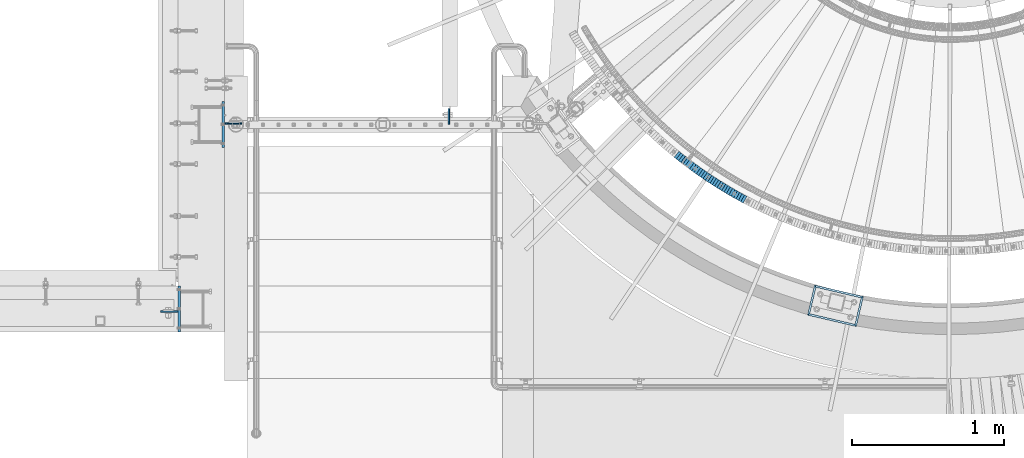
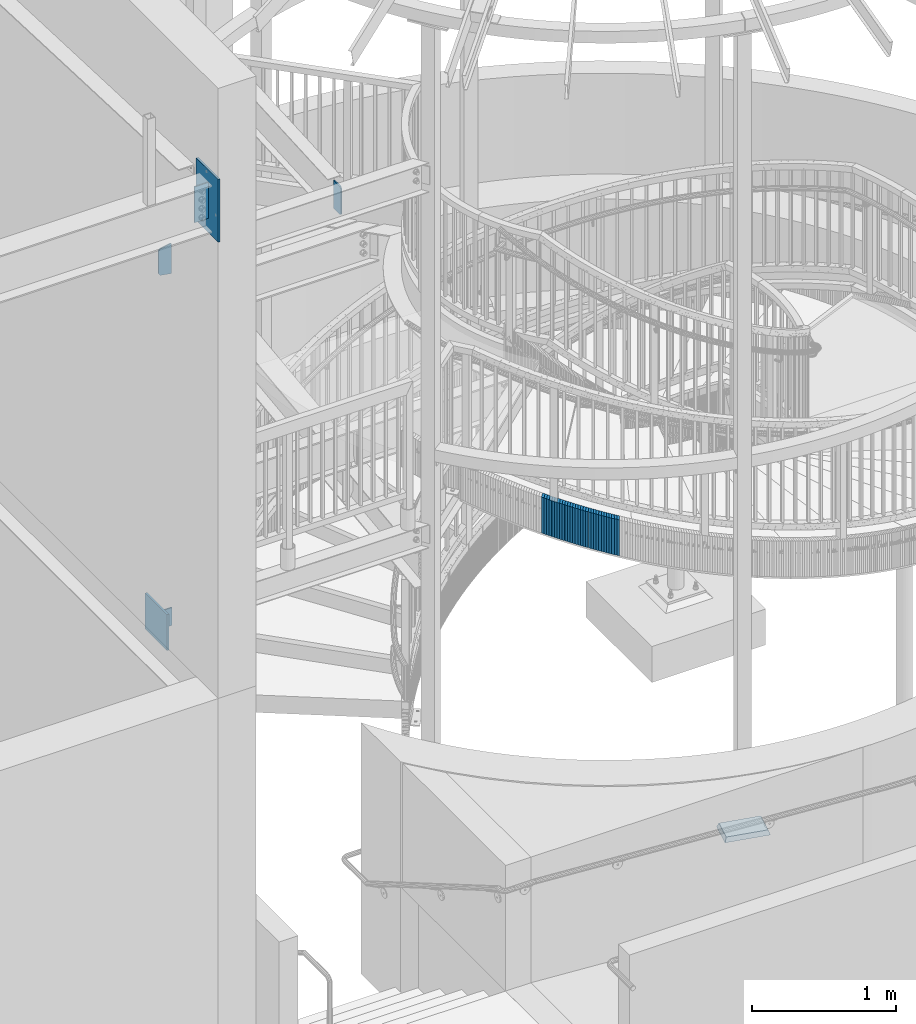
# One storey, part 873 of 975: 37 plates.
"""IFC2X3 building model written with IfcOpenShell, lengths in millimetres."""

from ifc_helpers import new_model, si_unit, frame, origin_with_axes, place, context, subcontext, project, spatial, faceted_brep, material, type_object, element, save


model = new_model("IFC2X3")

# Units and contexts
model_context = context("Model", 3, precision=1e-05, world=origin_with_axes())
body_context = subcontext(model_context, "Body", "Model", "MODEL_VIEW")
ifc_project = project(units=[si_unit("LENGTHUNIT", "METRE", prefix="MILLI"), si_unit("AREAUNIT", "SQUARE_METRE"), si_unit("VOLUMEUNIT", "CUBIC_METRE"), si_unit("MASSUNIT", "GRAM", prefix="KILO"), si_unit("TIMEUNIT", "SECOND"), si_unit("PLANEANGLEUNIT", "RADIAN"), si_unit("SOLIDANGLEUNIT", "STERADIAN"), si_unit("THERMODYNAMICTEMPERATUREUNIT", "DEGREE_CELSIUS"), si_unit("LUMINOUSINTENSITYUNIT", "LUMEN")], contexts=[model_context])

# Site, building, storey
site_placement = place(None, origin_with_axes())
site = spatial("IfcSite", under=ifc_project, at=site_placement, CompositionType="ELEMENT")
building_placement = place(site_placement, origin_with_axes())
building = spatial("IfcBuilding", under=site, at=building_placement, Name="Undefined", CompositionType="ELEMENT")
storey_placement = place(building_placement, origin_with_axes())
storey = spatial("IfcBuildingStorey", under=building, at=storey_placement, Name="Undefined", CompositionType="ELEMENT", Elevation=0.0)

# Plates
ifc_material_1 = material(Name="STEEL/A36")
plate_type_1 = type_object("IfcPlateType", PredefinedType="NOTDEFINED")
plate_1_placement = place(storey_placement, frame((29965.9498440442, 1372.15213761205, 6767.67232410142), z_axis=(0.164483633078449, 0.0, 0.986379812470488), x_axis=(0.986379812470487, 0.0, -0.16448363307845)))
element("IfcPlate", 1, at=plate_1_placement, inside=storey, type_object=plate_type_1, material=ifc_material_1, Name="PLATE", context=body_context, shape_type="Brep", body=[
    faceted_brep([(-2.35006011738005, -4.76249999999982, 14.0929019224332), (-34.1783212304363, -4.76249999999982, 204.961449884235), (-34.1783212304363, 4.76249999999982, 204.961449884235), (-2.35006011738005, 4.76249999999982, 14.0929019224332), (-23.0139741568892, -4.76249999999982, 223.690456359918), (-23.0139741568892, 4.76249999999982, 223.690456359918), (60.9010810849977, -4.76249999997867, 252.477432251004), (60.901081085005, 4.76250000002142, 252.477432251006), (103.002922058127, -4.762499999998, 2.72848410531878e-11), (103.002922058138, 4.76250000000186, 2.72848410531878e-11), (14.2875003814897, -4.76249999997526, 9.09494701772928e-12), (14.2875003814825, 4.76250000001892, 9.09494701772928e-12)], [[[0, 1, 2, 3]], [[1, 4, 5, 2]], [[4, 6, 7, 5]], [[6, 8, 9, 7]], [[8, 10, 11, 9]], [[10, 0, 3, 11]], [[5, 7, 9, 11, 3, 2]], [[10, 8, 6, 4, 1, 0]]]),
])
plate_2_placement = place(storey_placement, frame((31434.8810365989, 1367.38914717561, 6764.33750000007), z_axis=(0.0, 0.0, 1.0), x_axis=(0.0, 1.0, 0.0)))
element("IfcPlate", 2, at=plate_2_placement, inside=storey, type_object=plate_type_1, material=ifc_material_1, Name="PLATE", context=body_context, shape_type="Brep", body=[
    faceted_brep([(4.54747350886464e-13, -4.76250000000437, 14.2875003814697), (4.54747350886464e-13, -4.76250000000437, 227.012502670288), (0.0, 4.76249999999709, 227.012502670288), (0.0, 4.76249999999709, 14.2875003814697), (14.2875003814702, -4.76250000002983, 241.300003051758), (14.2875003814697, 4.76249999997162, 241.300003051758), (101.599998474122, -4.7625000001608, 241.300003051758), (101.599998474121, 4.76249999984066, 241.300003051758), (101.600006103516, -4.76250000000073, 0.0), (101.600006103516, 4.76250000000073, 0.0), (14.2875003814897, -4.76249999997526, 9.09494701772928e-12), (14.2875003814825, 4.76250000001892, 9.09494701772928e-12)], [[[0, 1, 2, 3]], [[1, 4, 5, 2]], [[4, 6, 7, 5]], [[6, 8, 9, 7]], [[8, 10, 11, 9]], [[10, 0, 3, 11]], [[5, 7, 9, 11, 3, 2]], [[10, 8, 6, 4, 1, 0]]]),
])
plate_type_2 = type_object("IfcPlateType", PredefinedType="NOTDEFINED")
plate_3_placement = place(storey_placement, frame((32945.7241902459, 1158.46817278171, 3676.3875000677), z_axis=(-0.780868809052787, 0.624695048042229, 0.0), x_axis=(0.0, 0.0, 1.0)))
element("IfcPlate", 3, at=plate_3_placement, inside=storey, type_object=plate_type_2, material=ifc_material_1, Name="WALL", context=body_context, shape_type="Brep", body=[
    faceted_brep([(0.0, -25.3999999999724, -1.81898940354586e-11), (5.80000019073486, -25.3999999999833, 17.9287471770986), (5.80000019073486, 25.4000000000087, 17.9287471771167), (0.0, 25.3999999999869, 1.45519152283669e-11), (310.600006103516, -25.3999999999833, 17.9287471770986), (310.600006103516, 25.4000000000087, 17.9287471771167), (304.799987792969, -25.3999999999724, -1.81898940354586e-11), (304.799987792969, 25.3999999999869, 1.45519152283669e-11)], [[[0, 1, 2, 3]], [[1, 4, 5, 2]], [[4, 6, 7, 5]], [[6, 0, 3, 7]], [[5, 7, 3, 2]], [[6, 4, 1, 0]]]),
])
plate_4_placement = place(storey_placement, frame((32959.8110283634, 1147.29901297474, 3670.6875000677), z_axis=(-0.783591636094264, 0.621276225074736, 0.0), x_axis=(0.0, 0.0, 1.0)))
element("IfcPlate", 4, at=plate_4_placement, inside=storey, type_object=plate_type_2, material=ifc_material_1, Name="WALL", context=body_context, shape_type="Brep", body=[
    faceted_brep([(0.0, -25.3999999999724, -1.81898940354586e-11), (5.69999980926514, -25.3999999999469, 17.8731651305425), (5.69999980926514, 25.3999999999869, 17.8731651306334), (0.0, 25.3999999999869, 1.45519152283669e-11), (310.5, -25.3999999999469, 17.8731651305425), (310.5, 25.3999999999869, 17.8731651306334), (304.799987792969, -25.3999999999724, -1.81898940354586e-11), (304.799987792969, 25.3999999999869, 1.45519152283669e-11)], [[[0, 1, 2, 3]], [[1, 4, 5, 2]], [[4, 6, 7, 5]], [[6, 0, 3, 7]], [[5, 7, 3, 2]], [[6, 4, 1, 0]]]),
])
plate_5_placement = place(storey_placement, frame((32974.2365418416, 1136.12227530397, 3664.9875000677), z_axis=(-0.79054981213442, 0.612397742104127, 0.0), x_axis=(0.0, 0.0, 1.0)))
element("IfcPlate", 5, at=plate_5_placement, inside=storey, type_object=plate_type_2, material=ifc_material_1, Name="WALL", context=body_context, shape_type="Brep", body=[
    faceted_brep([(0.0, -25.3999999999724, -1.81898940354586e-11), (5.69999980926514, -25.400000000016, 17.9627399444762), (5.69999980926514, 25.3999999999869, 17.9627399444762), (0.0, 25.3999999999869, 1.45519152283669e-11), (310.5, -25.400000000016, 17.9627399444762), (310.5, 25.3999999999869, 17.9627399444762), (304.799987792969, -25.3999999999724, -1.81898940354586e-11), (304.799987792969, 25.3999999999869, 1.45519152283669e-11)], [[[0, 1, 2, 3]], [[1, 4, 5, 2]], [[4, 6, 7, 5]], [[6, 0, 3, 7]], [[5, 7, 3, 2]], [[6, 4, 1, 0]]]),
])
plate_6_placement = place(storey_placement, frame((32988.5253707412, 1125.15377749335, 3659.1875000677), z_axis=(-0.793246576330857, 0.608900541253967, 0.0), x_axis=(0.0, 0.0, 1.0)))
element("IfcPlate", 6, at=plate_6_placement, inside=storey, type_object=plate_type_2, material=ifc_material_1, Name="WALL", context=body_context, shape_type="Brep", body=[
    faceted_brep([(0.0, -25.3999999999724, -1.81898940354586e-11), (5.80000019073486, -25.399999999936, 17.9011173247382), (5.80000019073486, 25.3999999999578, 17.9011173248837), (0.0, 25.3999999999869, 1.45519152283669e-11), (310.600006103516, -25.399999999936, 17.9011173247382), (310.600006103516, 25.3999999999578, 17.9011173248837), (304.799987792969, -25.3999999999724, -1.81898940354586e-11), (304.799987792969, 25.3999999999869, 1.45519152283669e-11)], [[[0, 1, 2, 3]], [[1, 4, 5, 2]], [[4, 6, 7, 5]], [[6, 0, 3, 7]], [[5, 7, 3, 2]], [[6, 4, 1, 0]]]),
])
plate_7_placement = place(storey_placement, frame((33002.8936910066, 1114.20151807421, 3653.3875000677), z_axis=(-0.795304033791869, 0.606210766841354, 0.0), x_axis=(0.0, 0.0, 1.0)))
element("IfcPlate", 7, at=plate_7_placement, inside=storey, type_object=plate_type_2, material=ifc_material_1, Name="WALL", context=body_context, shape_type="Brep", body=[
    faceted_brep([(0.0, -25.3999999999724, -1.81898940354586e-11), (5.80000019073486, -25.3999999999505, 17.9788761138298), (5.80000019073486, 25.4000000000196, 17.9788761138625), (0.0, 25.3999999999869, 1.45519152283669e-11), (310.600006103516, -25.3999999999505, 17.9788761138298), (310.600006103516, 25.4000000000196, 17.9788761138625), (304.799987792969, -25.3999999999724, -1.81898940354586e-11), (304.799987792969, 25.3999999999869, 1.45519152283669e-11)], [[[0, 1, 2, 3]], [[1, 4, 5, 2]], [[4, 6, 7, 5]], [[6, 0, 3, 7]], [[5, 7, 3, 2]], [[6, 4, 1, 0]]]),
])
plate_8_placement = place(storey_placement, frame((33017.2834945886, 1103.33338092226, 3647.6875000677), z_axis=(-0.797986598823975, 0.602675192867057, 0.0), x_axis=(0.0, 0.0, 1.0)))
element("IfcPlate", 8, at=plate_8_placement, inside=storey, type_object=plate_type_2, material=ifc_material_1, Name="WALL", context=body_context, shape_type="Brep", body=[
    faceted_brep([(0.0, -25.3999999999724, -1.81898940354586e-11), (5.69999980926514, -25.3999999999724, 17.9212169646999), (5.69999980926514, 25.3999999999651, 17.9212169647544), (0.0, 25.3999999999869, 1.45519152283669e-11), (310.5, -25.3999999999724, 17.9212169646999), (310.5, 25.3999999999651, 17.9212169647544), (304.799987792969, -25.3999999999724, -1.81898940354586e-11), (304.799987792969, 25.3999999999869, 1.45519152283669e-11)], [[[0, 1, 2, 3]], [[1, 4, 5, 2]], [[4, 6, 7, 5]], [[6, 0, 3, 7]], [[5, 7, 3, 2]], [[6, 4, 1, 0]]]),
])
plate_9_placement = place(storey_placement, frame((33031.6742087829, 1092.56518721397, 3641.9875000677), z_axis=(-0.800671390520529, 0.599103767641235, 0.0), x_axis=(0.0, 0.0, 1.0)))
element("IfcPlate", 9, at=plate_9_placement, inside=storey, type_object=plate_type_2, material=ifc_material_1, Name="WALL", context=body_context, shape_type="Brep", body=[
    faceted_brep([(0.0, -25.3999999999724, -1.81898940354586e-11), (5.69999980926514, -25.4000000000378, 17.8639297485788), (5.69999980926514, 25.3999999999833, 17.8639297485533), (0.0, 25.3999999999869, 1.45519152283669e-11), (310.5, -25.4000000000378, 17.8639297485788), (310.5, 25.3999999999833, 17.8639297485533), (304.799987792969, -25.3999999999724, -1.81898940354586e-11), (304.799987792969, 25.3999999999869, 1.45519152283669e-11)], [[[0, 1, 2, 3]], [[1, 4, 5, 2]], [[4, 6, 7, 5]], [[6, 0, 3, 7]], [[5, 7, 3, 2]], [[6, 4, 1, 0]]]),
])
plate_10_placement = place(storey_placement, frame((33046.4014777338, 1081.79709734652, 3636.1875000677), z_axis=(-0.807289101847685, 0.590156170888654, 0.0), x_axis=(0.0, 0.0, 1.0)))
element("IfcPlate", 10, at=plate_10_placement, inside=storey, type_object=plate_type_2, material=ifc_material_1, Name="WALL", context=body_context, shape_type="Brep", body=[
    faceted_brep([(0.0, -25.3999999999724, -1.81898940354586e-11), (5.80000019073486, -25.399999999976, 17.9610691070338), (5.80000019073486, 25.4000000000269, 17.9610691070338), (0.0, 25.3999999999869, 1.45519152283669e-11), (310.600006103516, -25.399999999976, 17.9610691070338), (310.600006103516, 25.4000000000269, 17.9610691070338), (304.799987792969, -25.3999999999724, -1.81898940354586e-11), (304.799987792969, 25.3999999999869, 1.45519152283669e-11)], [[[0, 1, 2, 3]], [[1, 4, 5, 2]], [[4, 6, 7, 5]], [[6, 0, 3, 7]], [[5, 7, 3, 2]], [[6, 4, 1, 0]]]),
])
plate_11_placement = place(storey_placement, frame((33060.9940952527, 1071.22971064023, 3630.4875000677), z_axis=(-0.80994212177235, 0.58650981183515, 0.0), x_axis=(0.0, 0.0, 1.0)))
element("IfcPlate", 11, at=plate_11_placement, inside=storey, type_object=plate_type_2, material=ifc_material_1, Name="WALL", context=body_context, shape_type="Brep", body=[
    faceted_brep([(0.0, -25.3999999999724, -1.81898940354586e-11), (5.69999980926514, -25.3999999999978, 17.9011173248218), (5.69999980926514, 25.4000000000087, 17.9011173248182), (0.0, 25.3999999999869, 1.45519152283669e-11), (310.5, -25.3999999999978, 17.9011173248218), (310.5, 25.4000000000087, 17.9011173248182), (304.799987792969, -25.3999999999724, -1.81898940354586e-11), (304.799987792969, 25.3999999999869, 1.45519152283669e-11)], [[[0, 1, 2, 3]], [[1, 4, 5, 2]], [[4, 6, 7, 5]], [[6, 0, 3, 7]], [[5, 7, 3, 2]], [[6, 4, 1, 0]]]),
])
plate_12_placement = place(storey_placement, frame((33075.5876275221, 1060.76230342808, 3624.6875000677), z_axis=(-0.812595949007106, 0.582827439005097, 0.0), x_axis=(0.0, 0.0, 1.0)))
element("IfcPlate", 12, at=plate_12_placement, inside=storey, type_object=plate_type_2, material=ifc_material_1, Name="WALL", context=body_context, shape_type="Brep", body=[
    faceted_brep([(0.0, -25.3999999999724, -1.81898940354586e-11), (5.80000019073486, -25.3999999999614, 17.8392829894583), (5.80000019073486, 25.3999999999578, 17.8392829895529), (0.0, 25.3999999999869, 1.45519152283669e-11), (310.600006103516, -25.3999999999614, 17.8392829894583), (310.600006103516, 25.3999999999578, 17.8392829895529), (304.799987792969, -25.3999999999724, -1.81898940354586e-11), (304.799987792969, 25.3999999999869, 1.45519152283669e-11)], [[[0, 1, 2, 3]], [[1, 4, 5, 2]], [[4, 6, 7, 5]], [[6, 0, 3, 7]], [[5, 7, 3, 2]], [[6, 4, 1, 0]]]),
])
plate_13_placement = place(storey_placement, frame((33090.3492730024, 1050.34731787968, 3618.9875000677), z_axis=(-0.817122939119162, 0.576463444084065, 0.0), x_axis=(0.0, 0.0, 1.0)))
element("IfcPlate", 13, at=plate_13_placement, inside=storey, type_object=plate_type_2, material=ifc_material_1, Name="WALL", context=body_context, shape_type="Brep", body=[
    faceted_brep([(0.0, -25.3999999999724, -1.81898940354586e-11), (5.69999980926514, -25.3999999999469, 17.8731651305425), (5.69999980926514, 25.3999999999869, 17.8731651306334), (0.0, 25.3999999999869, 1.45519152283669e-11), (310.5, -25.3999999999469, 17.8731651305425), (310.5, 25.3999999999869, 17.8731651306334), (304.799987792969, -25.3999999999724, -1.81898940354586e-11), (304.799987792969, 25.3999999999869, 1.45519152283669e-11)], [[[0, 1, 2, 3]], [[1, 4, 5, 2]], [[4, 6, 7, 5]], [[6, 0, 3, 7]], [[5, 7, 3, 2]], [[6, 4, 1, 0]]]),
])
plate_14_placement = place(storey_placement, frame((33105.2113731661, 1040.03390244274, 3613.2875000677), z_axis=(-0.821588113820831, 0.570081547875679, 0.0), x_axis=(0.0, 0.0, 1.0)))
element("IfcPlate", 14, at=plate_14_placement, inside=storey, type_object=plate_type_2, material=ifc_material_1, Name="WALL", context=body_context, shape_type="Brep", body=[
    faceted_brep([(0.0, -25.3999999999724, -1.81898940354586e-11), (5.69999980926514, -25.3999999999614, 17.8921775817616), (5.69999980926514, 25.400000000016, 17.8921775817726), (0.0, 25.3999999999869, 1.45519152283669e-11), (310.5, -25.3999999999614, 17.8921775817616), (310.5, 25.400000000016, 17.8921775817726), (304.799987792969, -25.3999999999724, -1.81898940354586e-11), (304.799987792969, 25.3999999999869, 1.45519152283669e-11)], [[[0, 1, 2, 3]], [[1, 4, 5, 2]], [[4, 6, 7, 5]], [[6, 0, 3, 7]], [[5, 7, 3, 2]], [[6, 4, 1, 0]]]),
])
plate_15_placement = place(storey_placement, frame((33120.1738930212, 1029.82206608943, 3607.4875000677), z_axis=(-0.825991119901672, 0.563683128932898, 0.0), x_axis=(0.0, 0.0, 1.0)))
element("IfcPlate", 15, at=plate_15_placement, inside=storey, type_object=plate_type_2, material=ifc_material_1, Name="WALL", context=body_context, shape_type="Brep", body=[
    faceted_brep([(0.0, -25.3999999999724, -1.81898940354586e-11), (5.80000019073486, -25.4000000000233, 17.9178676605334), (5.80000019073486, 25.3999999999942, 17.9178676605297), (0.0, 25.3999999999869, 1.45519152283669e-11), (310.600006103516, -25.4000000000233, 17.9178676605334), (310.600006103516, 25.3999999999942, 17.9178676605297), (304.799987792969, -25.3999999999724, -1.81898940354586e-11), (304.799987792969, 25.3999999999869, 1.45519152283669e-11)], [[[0, 1, 2, 3]], [[1, 4, 5, 2]], [[4, 6, 7, 5]], [[6, 0, 3, 7]], [[5, 7, 3, 2]], [[6, 4, 1, 0]]]),
])
plate_16_placement = place(storey_placement, frame((33135.0710662587, 1019.75608072524, 3601.7875000677), z_axis=(-0.828588968736746, 0.559857411210905, -1.04603259387659e-10), x_axis=(0.0, 0.0, 1.0)))
element("IfcPlate", 16, at=plate_16_placement, inside=storey, type_object=plate_type_2, material=ifc_material_1, Name="WALL", context=body_context, shape_type="Brep", body=[
    faceted_brep([(0.0, -25.3999999999724, -1.81898940354586e-11), (5.69999980926514, -25.4000000000378, 17.8639297485788), (5.69999980926514, 25.3999999999833, 17.8639297485533), (0.0, 25.3999999999869, 1.45519152283669e-11), (310.5, -25.4000000000378, 17.8639297485788), (310.5, 25.3999999999833, 17.8639297485533), (304.799987792969, -25.3999999999724, -1.81898940354586e-11), (304.799987792969, 25.3999999999869, 1.45519152283669e-11)], [[[0, 1, 2, 3]], [[1, 4, 5, 2]], [[4, 6, 7, 5]], [[6, 0, 3, 7]], [[5, 7, 3, 2]], [[6, 4, 1, 0]]]),
])
plate_17_placement = place(storey_placement, frame((33149.9691575141, 1009.79013475099, 3596.0875000677), z_axis=(-0.831185267125649, 0.555995550084048, 0.0), x_axis=(0.0, 0.0, 1.0)))
element("IfcPlate", 17, at=plate_17_placement, inside=storey, type_object=plate_type_2, material=ifc_material_1, Name="WALL", context=body_context, shape_type="Brep", body=[
    faceted_brep([(0.0, -25.3999999999724, -1.81898940354586e-11), (5.69999980926514, -25.4000000000306, 17.8058986664291), (5.69999980926514, 25.4000000000415, 17.80589866632), (0.0, 25.3999999999869, 1.45519152283669e-11), (310.5, -25.4000000000306, 17.8058986664291), (310.5, 25.4000000000415, 17.80589866632), (304.799987792969, -25.3999999999724, -1.81898940354586e-11), (304.799987792969, 25.3999999999869, 1.45519152283669e-11)], [[[0, 1, 2, 3]], [[1, 4, 5, 2]], [[4, 6, 7, 5]], [[6, 0, 3, 7]], [[5, 7, 3, 2]], [[6, 4, 1, 0]]]),
])
plate_18_placement = place(storey_placement, frame((33165.0338012818, 999.880925872626, 3590.2875000677), z_axis=(-0.835484829267466, 0.549513512175918, 0.0), x_axis=(0.0, 0.0, 1.0)))
element("IfcPlate", 18, at=plate_18_placement, inside=storey, type_object=plate_type_2, material=ifc_material_1, Name="WALL", context=body_context, shape_type="Brep", body=[
    faceted_brep([(0.0, -25.3999999999724, -1.81898940354586e-11), (5.80000019073486, -25.3999999999796, 17.8280677795228), (5.80000019073486, 25.4000000000196, 17.8280677795265), (0.0, 25.3999999999869, 1.45519152283669e-11), (310.600006103516, -25.3999999999796, 17.8280677795228), (310.600006103516, 25.4000000000196, 17.8280677795265), (304.799987792969, -25.3999999999724, -1.81898940354586e-11), (304.799987792969, 25.3999999999869, 1.45519152283669e-11)], [[[0, 1, 2, 3]], [[1, 4, 5, 2]], [[4, 6, 7, 5]], [[6, 0, 3, 7]], [[5, 7, 3, 2]], [[6, 4, 1, 0]]]),
])
plate_19_placement = place(storey_placement, frame((33180.1987583437, 990.073344439864, 3584.5875000677), z_axis=(-0.83972031877, 0.543019139851267, 0.0), x_axis=(0.0, 0.0, 1.0)))
element("IfcPlate", 19, at=plate_19_placement, inside=storey, type_object=plate_type_2, material=ifc_material_1, Name="WALL", context=body_context, shape_type="Brep", body=[
    faceted_brep([(0.0, -25.3999999999724, -1.81898940354586e-11), (5.69999980926514, -25.4000000000378, 17.8639297485788), (5.69999980926514, 25.3999999999833, 17.8639297485533), (0.0, 25.3999999999869, 1.45519152283669e-11), (310.5, -25.4000000000378, 17.8639297485788), (310.5, 25.3999999999833, 17.8639297485533), (304.799987792969, -25.3999999999724, -1.81898940354586e-11), (304.799987792969, 25.3999999999869, 1.45519152283669e-11)], [[[0, 1, 2, 3]], [[1, 4, 5, 2]], [[4, 6, 7, 5]], [[6, 0, 3, 7]], [[5, 7, 3, 2]], [[6, 4, 1, 0]]]),
])
plate_20_placement = place(storey_placement, frame((33195.3633554029, 980.331710123816, 3578.8875000677), z_axis=(-0.841359465121331, 0.54047594807794, 0.0), x_axis=(0.0, 0.0, 1.0)))
element("IfcPlate", 20, at=plate_20_placement, inside=storey, type_object=plate_type_2, material=ifc_material_1, Name="WALL", context=body_context, shape_type="Brep", body=[
    faceted_brep([(0.0, -25.3999999999724, -1.81898940354586e-11), (5.69999980926514, -25.4000000000342, 17.9493732452938), (5.69999980926514, 25.4000000000415, 17.9493732451738), (0.0, 25.3999999999869, 1.45519152283669e-11), (310.5, -25.4000000000342, 17.9493732452938), (310.5, 25.4000000000415, 17.9493732451738), (304.799987792969, -25.3999999999724, -1.81898940354586e-11), (304.799987792969, 25.3999999999869, 1.45519152283669e-11)], [[[0, 1, 2, 3]], [[1, 4, 5, 2]], [[4, 6, 7, 5]], [[6, 0, 3, 7]], [[5, 7, 3, 2]], [[6, 4, 1, 0]]]),
])
plate_21_placement = place(storey_placement, frame((33210.6655407199, 970.703172471536, 3573.1875000677), z_axis=(-0.846420002588977, 0.53251589574141, 0.0), x_axis=(0.0, 0.0, 1.0)))
element("IfcPlate", 21, at=plate_21_placement, inside=storey, type_object=plate_type_2, material=ifc_material_1, Name="WALL", context=body_context, shape_type="Brep", body=[
    faceted_brep([(0.0, -25.3999999999724, -1.81898940354586e-11), (5.69999980926514, -25.3999999999651, 17.8440475463649), (5.69999980926514, 25.3999999999942, 17.8440475463904), (0.0, 25.3999999999869, 1.45519152283669e-11), (310.5, -25.3999999999651, 17.8440475463649), (310.5, 25.3999999999942, 17.8440475463904), (304.799987792969, -25.3999999999724, -1.81898940354586e-11), (304.799987792969, 25.3999999999869, 1.45519152283669e-11)], [[[0, 1, 2, 3]], [[1, 4, 5, 2]], [[4, 6, 7, 5]], [[6, 0, 3, 7]], [[5, 7, 3, 2]], [[6, 4, 1, 0]]]),
])
plate_22_placement = place(storey_placement, frame((33225.8680014846, 961.239050189992, 3567.3875000677), z_axis=(-0.848944501891445, 0.528482007932424, 0.0), x_axis=(0.0, 0.0, 1.0)))
element("IfcPlate", 22, at=plate_22_placement, inside=storey, type_object=plate_type_2, material=ifc_material_1, Name="WALL", context=body_context, shape_type="Brep", body=[
    faceted_brep([(0.0, -25.3999999999724, -1.81898940354586e-11), (5.80000019073486, -25.4000000000124, 17.7912902832286), (5.80000019073486, 25.3999999999833, 17.7912902832286), (0.0, 25.3999999999869, 1.45519152283669e-11), (310.600006103516, -25.4000000000124, 17.7912902832286), (310.600006103516, 25.3999999999833, 17.7912902832286), (304.799987792969, -25.3999999999724, -1.81898940354586e-11), (304.799987792969, 25.3999999999869, 1.45519152283669e-11)], [[[0, 1, 2, 3]], [[1, 4, 5, 2]], [[4, 6, 7, 5]], [[6, 0, 3, 7]], [[5, 7, 3, 2]], [[6, 4, 1, 0]]]),
])
plate_23_placement = place(storey_placement, frame((33241.2951575237, 951.760411761357, 3561.6875000677), z_axis=(-0.852040503004264, 0.52347586500262, 0.0), x_axis=(0.0, 0.0, 1.0)))
element("IfcPlate", 23, at=plate_23_placement, inside=storey, type_object=plate_type_2, material=ifc_material_1, Name="WALL", context=body_context, shape_type="Brep", body=[
    faceted_brep([(0.0, -25.3999999999724, -1.81898940354586e-11), (5.69999980926514, -25.400000000016, 17.9627399444762), (5.69999980926514, 25.3999999999869, 17.9627399444762), (0.0, 25.3999999999869, 1.45519152283669e-11), (310.5, -25.400000000016, 17.9627399444762), (310.5, 25.3999999999869, 17.9627399444762), (304.799987792969, -25.3999999999724, -1.81898940354586e-11), (304.799987792969, 25.3999999999869, 1.45519152283669e-11)], [[[0, 1, 2, 3]], [[1, 4, 5, 2]], [[4, 6, 7, 5]], [[6, 0, 3, 7]], [[5, 7, 3, 2]], [[6, 4, 1, 0]]]),
])
plate_24_placement = place(storey_placement, frame((33256.6392564392, 942.472538527432, 3555.9875000677), z_axis=(-0.855500079193094, 0.517802679116872, 0.0), x_axis=(0.0, 0.0, 1.0)))
element("IfcPlate", 24, at=plate_24_placement, inside=storey, type_object=plate_type_2, material=ifc_material_1, Name="WALL", context=body_context, shape_type="Brep", body=[
    faceted_brep([(0.0, -25.3999999999724, -1.81898940354586e-11), (5.69999980926514, -25.400000000056, 17.7673854828754), (5.69999980926514, 25.3999999999833, 17.7673854828172), (0.0, 25.3999999999869, 1.45519152283669e-11), (310.5, -25.400000000056, 17.7673854828754), (310.5, 25.3999999999833, 17.7673854828172), (304.799987792969, -25.3999999999724, -1.81898940354586e-11), (304.799987792969, 25.3999999999869, 1.45519152283669e-11)], [[[0, 1, 2, 3]], [[1, 4, 5, 2]], [[4, 6, 7, 5]], [[6, 0, 3, 7]], [[5, 7, 3, 2]], [[6, 4, 1, 0]]]),
])
plate_25_placement = place(storey_placement, frame((33272.2697199569, 933.234706722863, 3550.2875000677), z_axis=(-0.860926528214316, 0.508729312126641, 0.0), x_axis=(0.0, 0.0, 1.0)))
element("IfcPlate", 25, at=plate_25_placement, inside=storey, type_object=plate_type_2, material=ifc_material_1, Name="WALL", context=body_context, shape_type="Brep", body=[
    faceted_brep([(0.0, -25.3999999999724, -1.81898940354586e-11), (5.69999980926514, -25.3999999999614, 17.8921775817616), (5.69999980926514, 25.400000000016, 17.8921775817726), (0.0, 25.3999999999869, 1.45519152283669e-11), (310.5, -25.3999999999614, 17.8921775817616), (310.5, 25.400000000016, 17.8921775817726), (304.799987792969, -25.3999999999724, -1.81898940354586e-11), (304.799987792969, 25.3999999999869, 1.45519152283669e-11)], [[[0, 1, 2, 3]], [[1, 4, 5, 2]], [[4, 6, 7, 5]], [[6, 0, 3, 7]], [[5, 7, 3, 2]], [[6, 4, 1, 0]]]),
])
plate_26_placement = place(storey_placement, frame((33287.6697199531, 924.134706722872, 3544.4875000677), z_axis=(-0.860926528214316, 0.508729312126641, 0.0), x_axis=(0.0, 0.0, 1.0)))
element("IfcPlate", 26, at=plate_26_placement, inside=storey, type_object=plate_type_2, material=ifc_material_1, Name="WALL", context=body_context, shape_type="Brep", body=[
    faceted_brep([(0.0, -25.3999999999724, -1.81898940354586e-11), (5.80000019073486, -25.4000000000451, 17.8891029358201), (5.80000019073486, 25.4000000000087, 17.8891029357856), (0.0, 25.3999999999869, 1.45519152283669e-11), (310.600006103516, -25.4000000000451, 17.8891029358201), (310.600006103516, 25.4000000000087, 17.8891029357856), (304.799987792969, -25.3999999999724, -1.81898940354586e-11), (304.799987792969, 25.3999999999869, 1.45519152283669e-11)], [[[0, 1, 2, 3]], [[1, 4, 5, 2]], [[4, 6, 7, 5]], [[6, 0, 3, 7]], [[5, 7, 3, 2]], [[6, 4, 1, 0]]]),
])
for number, where, z_axis, x_axis, name in (
    (27, (33303.4436301932, 915.075148268557, 3538.7875000677), (-0.867208357151329, 0.497945444086893, 0.0), (0.0, 0.0, 1.0), "WALL"),
    (28, (33318.943630185, 906.175148268605, 3533.0875000677), (-0.867208357151329, 0.497945444086893, 0.0), (0.0, 0.0, 1.0), "WALL"),
):
    element("IfcPlate", number, at=place(storey_placement, frame(where, z_axis=z_axis, x_axis=x_axis)), inside=storey, type_object=plate_type_2, material=ifc_material_1, Name=name, context=body_context, shape_type="Brep", body=[
        faceted_brep([(0.0, -25.3999999999724, -1.81898940354586e-11), (5.69999980926514, -25.3999999999469, 17.8731651305425), (5.69999980926514, 25.3999999999869, 17.8731651306334), (0.0, 25.3999999999869, 1.45519152283669e-11), (310.5, -25.3999999999469, 17.8731651305425), (310.5, 25.3999999999869, 17.8731651306334), (304.799987792969, -25.3999999999724, -1.81898940354586e-11), (304.799987792969, 25.3999999999869, 1.45519152283669e-11)], [[[0, 1, 2, 3]], [[1, 4, 5, 2]], [[4, 6, 7, 5]], [[6, 0, 3, 7]], [[5, 7, 3, 2]], [[6, 4, 1, 0]]]),
    ])
plate_27_placement = place(storey_placement, frame((33334.8199092552, 897.318798139819, 3527.2875000677), z_axis=(-0.873363874050119, 0.487068315027951, 0.0), x_axis=(0.0, 0.0, 1.0)))
element("IfcPlate", 29, at=plate_27_placement, inside=storey, type_object=plate_type_2, material=ifc_material_1, Name="WALL", context=body_context, shape_type="Brep", body=[
    faceted_brep([(0.0, -25.3999999999724, -1.81898940354586e-11), (5.80000019073486, -25.4000000000378, 17.8600120545088), (5.80000019073486, 25.3999999999942, 17.8600120544543), (0.0, 25.3999999999869, 1.45519152283669e-11), (310.600006103516, -25.4000000000378, 17.8600120545088), (310.600006103516, 25.3999999999942, 17.8600120544543), (304.799987792969, -25.3999999999724, -1.81898940354586e-11), (304.799987792969, 25.3999999999869, 1.45519152283669e-11)], [[[0, 1, 2, 3]], [[1, 4, 5, 2]], [[4, 6, 7, 5]], [[6, 0, 3, 7]], [[5, 7, 3, 2]], [[6, 4, 1, 0]]]),
])
plate_28_placement = place(storey_placement, frame((33350.4199092472, 888.61879813958, 3521.5875000677), z_axis=(-0.873363874050119, 0.487068315027951, 0.0), x_axis=(0.0, 0.0, 1.0)))
element("IfcPlate", 30, at=plate_28_placement, inside=storey, type_object=plate_type_2, material=ifc_material_1, Name="WALL", context=body_context, shape_type="Brep", body=[
    faceted_brep([(0.0, -25.3999999999724, -1.81898940354586e-11), (5.69999980926514, -25.4000000000378, 17.8639297485788), (5.69999980926514, 25.3999999999833, 17.8639297485533), (0.0, 25.3999999999869, 1.45519152283669e-11), (310.5, -25.4000000000378, 17.8639297485788), (310.5, 25.3999999999833, 17.8639297485533), (304.799987792969, -25.3999999999724, -1.81898940354586e-11), (304.799987792969, 25.3999999999869, 1.45519152283669e-11)], [[[0, 1, 2, 3]], [[1, 4, 5, 2]], [[4, 6, 7, 5]], [[6, 0, 3, 7]], [[5, 7, 3, 2]], [[6, 4, 1, 0]]]),
])
plate_29_placement = place(storey_placement, frame((33366.3984359466, 879.965742488401, 3515.8875000677), z_axis=(-0.879389687135148, 0.476102697073171, 0.0), x_axis=(0.0, 0.0, 1.0)))
element("IfcPlate", 31, at=plate_29_placement, inside=storey, type_object=plate_type_2, material=ifc_material_1, Name="WALL", context=body_context, shape_type="Brep", body=[
    faceted_brep([(0.0, -25.3999999999724, -1.81898940354586e-11), (5.69999980926514, -25.4000000000196, 17.8538513183848), (5.69999980926514, 25.4000000000415, 17.8538513183157), (0.0, 25.3999999999869, 1.45519152283669e-11), (310.5, -25.4000000000196, 17.8538513183848), (310.5, 25.4000000000415, 17.8538513183157), (304.799987792969, -25.3999999999724, -1.81898940354586e-11), (304.799987792969, 25.3999999999869, 1.45519152283669e-11)], [[[0, 1, 2, 3]], [[1, 4, 5, 2]], [[4, 6, 7, 5]], [[6, 0, 3, 7]], [[5, 7, 3, 2]], [[6, 4, 1, 0]]]),
])
plate_30_placement = place(storey_placement, frame((33382.2577522102, 871.433730286108, 3510.0875000677), z_axis=(-0.88065001007105, 0.473767411038222, 0.0), x_axis=(0.0, 0.0, 1.0)))
element("IfcPlate", 32, at=plate_30_placement, inside=storey, type_object=plate_type_2, material=ifc_material_1, Name="WALL", context=body_context, shape_type="Brep", body=[
    faceted_brep([(0.0, -25.3999999999724, -1.81898940354586e-11), (5.80000019073486, -25.3999999999614, 17.9424076079595), (5.80000019073486, 25.3999999999978, 17.9424076080322), (0.0, 25.3999999999869, 1.45519152283669e-11), (310.600006103516, -25.3999999999614, 17.9424076079595), (310.600006103516, 25.3999999999978, 17.9424076080322), (304.799987792969, -25.3999999999724, -1.81898940354586e-11), (304.799987792969, 25.3999999999869, 1.45519152283669e-11)], [[[0, 1, 2, 3]], [[1, 4, 5, 2]], [[4, 6, 7, 5]], [[6, 0, 3, 7]], [[5, 7, 3, 2]], [[6, 4, 1, 0]]]),
])
plate_type_3 = type_object("IfcPlateType", PredefinedType="NOTDEFINED")
plate_31_placement = place(storey_placement, frame((29654.499963295, 135.73125, 8420.1), z_axis=(-0.999999999999998, 6.90000001668524e-08, 0.0), x_axis=(0.0, 0.0, -1.0)))
element("IfcPlate", 33, at=plate_31_placement, inside=storey, type_object=plate_type_3, material=ifc_material_1, Name="PLATE", context=body_context, shape_type="Brep", body=[
    faceted_brep([(0.0, -4.76250000000073, 0.0), (0.0, -4.76249999999982, 114.300003051758), (0.0, 4.76249999999982, 114.300003051758), (0.0, 4.76250000000073, 0.0), (304.799987792969, -4.76249999999982, 114.300003051758), (304.799987792969, 4.76249999999982, 114.300003051758), (304.799987792969, -4.76249999999982, 0.0), (304.799987792969, 4.76249999999982, 0.0)], [[[0, 1, 2, 3]], [[1, 4, 5, 2]], [[4, 6, 7, 5]], [[6, 0, 3, 7]], [[5, 7, 3, 2]], [[6, 4, 1, 0]]]),
])
plate_32_placement = place(storey_placement, frame((29959.3000000636, 1372.13882678874, 3911.6), z_axis=(1.0, 0.0, 0.0), x_axis=(0.0, 0.0, -1.0)))
element("IfcPlate", 34, at=plate_32_placement, inside=storey, type_object=plate_type_3, material=ifc_material_1, Name="PLATE", context=body_context, shape_type="Brep", body=[
    faceted_brep([(0.0, -4.76250000000073, 0.0), (0.0, -4.76249999999982, 114.300003051758), (0.0, 4.76249999999982, 114.300003051758), (0.0, 4.76250000000073, 0.0), (152.399993896484, -4.76249999998913, 114.300003051761), (152.399993896484, 4.76250000001096, 114.300003051761), (152.399993896484, -4.76250000000073, 0.0), (152.399993896484, 4.76250000000073, 0.0)], [[[0, 1, 2, 3]], [[1, 4, 5, 2]], [[4, 6, 7, 5]], [[6, 0, 3, 7]], [[5, 7, 3, 2]], [[6, 4, 1, 0]]]),
])
plate_type_4 = type_object("IfcPlateType", PredefinedType="NOTDEFINED")
plate_33_placement = place(storey_placement, frame((29662.437463295, 0.0, 8523.2875), z_axis=(0.0, 0.0, -1.0), x_axis=(0.0, 1.0, 0.0)))
element("IfcPlate", 35, at=plate_33_placement, inside=storey, type_object=plate_type_4, material=ifc_material_1, Name="EMBED", context=body_context, shape_type="Brep", body=[
    faceted_brep([(-4.22995071858168e-07, -7.93750000000728, 0.0), (0.0, -7.9375, 533.400024414062), (0.0, 7.9375, 533.400024414062), (4.22980519942939e-07, 7.93750000001091, 0.0), (304.799987792969, -7.9375, 533.400024414062), (304.799987792969, 7.9375, 533.400024414062), (304.799987792969, -7.9375, 0.0), (304.799987792969, 7.9375, 0.0)], [[[0, 1, 2, 3]], [[1, 4, 5, 2]], [[4, 6, 7, 5]], [[6, 0, 3, 7]], [[5, 7, 3, 2]], [[6, 4, 1, 0]]]),
])
plate_34_placement = place(storey_placement, frame((29951.362501371, 1517.39507685979, 3989.3875), z_axis=(0.0, 0.0, -1.0), x_axis=(0.0, -1.0, 0.0)))
element("IfcPlate", 36, at=plate_34_placement, inside=storey, type_object=plate_type_4, material=ifc_material_1, Name="EMBED", context=body_context, shape_type="Brep", body=[
    faceted_brep([(-4.22995071858168e-07, -7.93750000000728, 0.0), (-9.09494701772928e-13, -7.93750000000364, 304.799987792969), (6.82121026329696e-13, 7.93749999999636, 304.799987792969), (4.22980519942939e-07, 7.93750000001091, 0.0), (304.799987792968, -7.9374999998945, 304.799987792969), (304.799987792969, 7.9375000001055, 304.799987792969), (304.799987792969, -7.9375, 0.0), (304.799987792969, 7.9375, 0.0)], [[[0, 1, 2, 3]], [[1, 4, 5, 2]], [[4, 6, 7, 5]], [[6, 0, 3, 7]], [[5, 7, 3, 2]], [[6, 4, 1, 0]]]),
])
ifc_material_2 = material(Name="CONCRETE/GROUT")
plate_type_5 = type_object("IfcPlateType", PredefinedType="NOTDEFINED")
plate_35_placement = place(storey_placement, frame((34160.2588555643, 234.741457873103, 1390.65), z_axis=(-0.228520788077446, -0.973539033329667, 0.0), x_axis=(-0.973539033329667, 0.228520788077446, 0.0)))
element("IfcPlate", 37, at=plate_35_placement, inside=storey, type_object=plate_type_5, material=ifc_material_2, Name="GROUT", context=body_context, shape_type="Brep", body=[
    faceted_brep([(330.200012367033, 19.0500013667977, 203.199997417756), (1.09139364212751e-11, 19.05, 203.199996948282), (12.7000000020234, -19.0499999844749, 190.500000003405), (317.500000003602, -19.049999999379, 190.499999996773), (330.200012206657, 19.0500004884277, -1.48389517562464e-07), (317.499999999585, -19.0499999999586, 12.6999999966938), (12.6999999980108, -19.0499999989649, 12.7000000033258), (2.63382389675826e-07, 19.0500000000138, 0.0)], [[[0, 1, 2, 3]], [[4, 5, 6, 7]], [[5, 4, 0, 3]], [[6, 5, 3, 2]], [[7, 6, 2, 1]], [[4, 7, 1, 0]]]),
])

save(model, "model.ifc")
